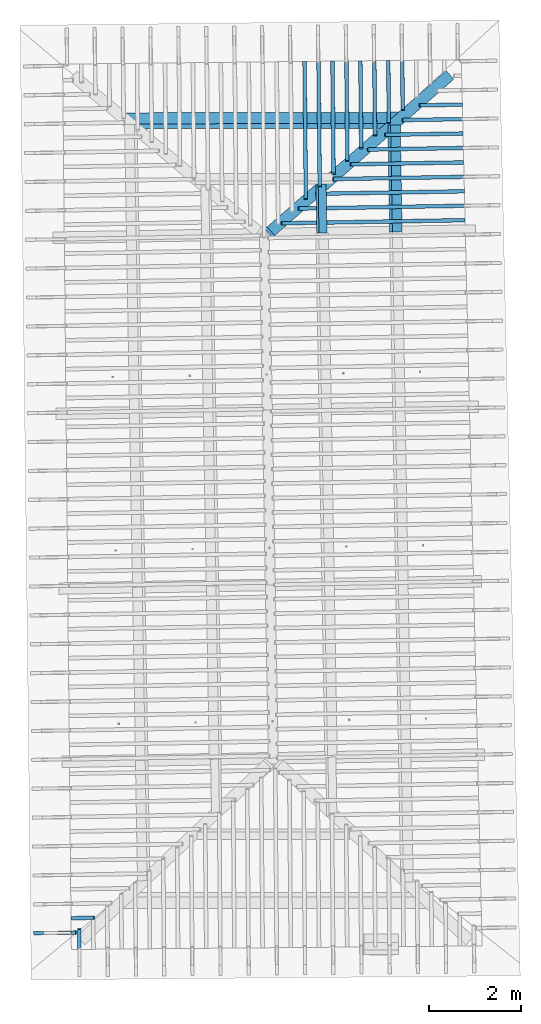
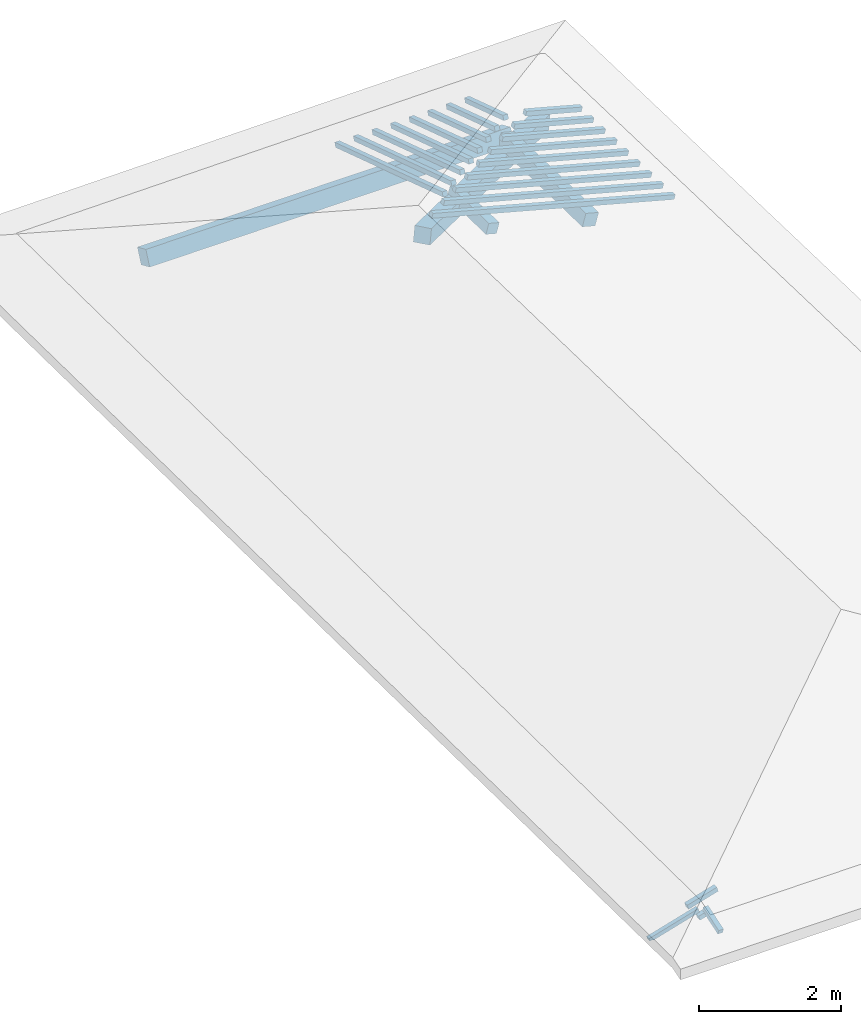
# One storey, part 8 of 19: 22 beams, 3 members, 5 elements without a shape of their own.
"""IFC4 building model written with IfcOpenShell, lengths in metres."""

from ifc_helpers import new_model, entity, si_unit, converted_unit, derived_unit, direction, frame, origin, place, context, subcontext, project, spatial, line, arc, indexed_curve, outline, extrude, source, transform, mapped, material, type_object, type_shapes, element, aggregate, save


model = new_model("IFC4")

# Units and contexts
model_context = context("Model", 3, precision=1e-05, world=origin(), true_north=direction((6.123233995736766e-17, 1.0)))
body_context = subcontext(model_context, "Body", "Model", "MODEL_VIEW")
ifc_project = project(units=[si_unit("LENGTHUNIT", "METRE"), si_unit("AREAUNIT", "SQUARE_METRE"), si_unit("VOLUMEUNIT", "CUBIC_METRE"), converted_unit("PLANEANGLEUNIT", "DEGREE", entity("IfcPlaneAngleMeasure", 0.017453292519943278), si_unit("PLANEANGLEUNIT", "RADIAN"), dimensions=[0, 0, 0, 0, 0, 0, 0]), derived_unit("THERMALTRANSMITTANCEUNIT", [(si_unit("MASSUNIT", "GRAM", prefix="KILO"), 1), (si_unit("THERMODYNAMICTEMPERATUREUNIT", "KELVIN"), -1), (si_unit("TIMEUNIT", "SECOND"), -3)])], contexts=[model_context])

# Site, building, storey
site_placement = place(None, origin())
site = spatial("IfcSite", under=ifc_project, at=site_placement, CompositionType="ELEMENT")
building_placement = place(site_placement, origin())
building = spatial("IfcBuilding", under=site, at=building_placement, CompositionType="ELEMENT")
storey_placement = place(building_placement, frame((0.0, 0.0, 3.28)))
storey = spatial("IfcBuildingStorey", under=building, at=storey_placement, Name="Livello Copertura", CompositionType="ELEMENT", Elevation=3.28)

# Beam
ifc_material = material(Name="Legno - Legno da costruzione", Category="Legno")
beam_type_1 = type_object("IfcBeamType", Name="Legno:250x250", PredefinedType="BEAM", material=ifc_material)
shared_shape_1 = source(origin(), body_context, "Body", "SweptSolid", [
    extrude(outline(indexed_curve([(-0.12500000000000164, -2.6915000000000004), (0.12500000000000164, -2.6915000000000004), (0.12500000000000164, 2.6915000000000004), (-0.12500000000000164, 2.6915000000000004), (-0.12500000000000164, -2.6915000000000004)], self_intersect=False)), frame((-0.09700000000000014, 0.0, -0.1250000000000054), z_axis=(0.0, 0.0, 1.0), x_axis=(0.0, 1.0, 0.0)), (0.0, 0.0, 1.0), 0.2499999999999999),
])
type_shapes(beam_type_1, [shared_shape_1])
beam_1_placement = place(storey_placement, frame((1.6960485545222057, 14.058149591074299, 0.36371203683741005), z_axis=(0.20387202036848304, 0.1778479374329003, 0.9627078011846253), x_axis=(-0.725463051111557, -0.6328583348061766, 0.2705433228491585)))
element("IfcBeam", 1, at=beam_1_placement, inside=storey, type_object=beam_type_1, material=ifc_material, Name="Legno:250x250", ObjectType="Legno:250x250", PredefinedType="BEAM", context=body_context, shape_type="MappedRepresentation", body=[
    mapped(shared_shape_1, transform((0.0, 0.0, 0.0), scale=1.0)),
])

# Members
member_type_1 = type_object("IfcMemberType", Name="Legno:220x220", PredefinedType="PURLIN", material=ifc_material)
shared_shape_2 = source(origin(), body_context, "Body", "SweptSolid", [
    extrude(outline(indexed_curve([(-1.1638894306878416, -0.11000000000000167), (1.1638894306878416, -0.11000000000000167), (1.1638894306878416, 0.11000000000000167), (-1.1638894306878416, 0.11000000000000167), (-1.1638894306878416, -0.11000000000000167)], self_intersect=False)), frame((0.7551105693121586, 0.0, -0.11000000000000543), z_axis=(0.0, 0.0, 1.0), x_axis=(-1.0, 0.0, 0.0)), (0.0, 0.0, 1.0), 0.21999999999999986),
])
type_shapes(member_type_1, [shared_shape_2])
member_1_placement = place(storey_placement, frame((2.531422696002869, 14.344178909537812, 0.36732198107242414), z_axis=(0.2688805697365734, 0.004594468182740755, 0.9631625667976581), x_axis=(0.017084897015614563, -0.9998540424951863, 0.0)))
element("IfcMember", 2, at=member_1_placement, inside=storey, type_object=member_type_1, material=ifc_material, Name="Legno:220x220", ObjectType="Legno:220x220", PredefinedType="PURLIN", context=body_context, shape_type="MappedRepresentation", body=[
    mapped(shared_shape_2, transform((0.0, 0.0, 0.0), scale=1.0)),
])
member_type_2 = type_object("IfcMemberType", Name="Legno:265x265", PredefinedType="PURLIN", material=ifc_material)
shared_shape_3 = source(origin(), body_context, "Body", "SweptSolid", [
    extrude(outline(indexed_curve([(-2.9789918250173737, -0.13250000000000164), (2.9789918250173737, -0.13250000000000164), (2.9789918250173737, 0.13250000000000164), (-2.9789918250173737, 0.13250000000000164), (-2.9789918250173737, -0.13250000000000164)], self_intersect=False)), frame((-0.06586492484490912, 0.0, -0.13250000000000545), z_axis=(0.0, 0.0, 1.0), x_axis=(-1.0, 0.0, 0.0)), (0.0, 0.0, 1.0), 0.2649999999999999),
])
type_shapes(member_type_2, [shared_shape_3])
member_2_placement = place(storey_placement, frame((-0.28854606470971034, 14.852295066283078, 0.3283530536152865), z_axis=(-0.003827735091052196, 0.39970199506726445, 0.9166371493580877), x_axis=(0.999992471364468, 0.002113791127369677, 0.0032540899577913683)))
element("IfcMember", 3, at=member_2_placement, inside=storey, type_object=member_type_2, material=ifc_material, Name="Legno:265x265", ObjectType="Legno:265x265", PredefinedType="PURLIN", context=body_context, shape_type="MappedRepresentation", body=[
    mapped(shared_shape_3, transform((0.0, 0.0, 0.0), scale=1.0)),
])
member_type_3 = type_object("IfcMemberType", Name="Legno:180x180", PredefinedType="PURLIN", material=ifc_material)
shared_shape_4 = source(origin(), body_context, "Body", "SweptSolid", [
    extrude(outline(indexed_curve([(-0.5343032276664149, -0.09000000000000168), (0.5343032276664149, -0.09000000000000168), (0.5343032276664149, 0.09000000000000168), (-0.5343032276664149, 0.09000000000000168), (-0.5343032276664149, -0.09000000000000168)], self_intersect=False)), frame((1.3846967723335852, 0.0, -0.09000000000000546), z_axis=(0.0, 0.0, 1.0), x_axis=(-1.0, 0.0, 0.0)), (0.0, 0.0, 1.0), 0.17999999999999997),
])
type_shapes(member_type_3, [shared_shape_4])
member_3_placement = place(storey_placement, frame((0.9179413523812053, 14.315851466891448, 0.7968332988440378), z_axis=(0.2688805697365734, 0.004594468182740752, 0.9631625667976581), x_axis=(0.017084897015614553, -0.9998540424951863, 0.0)))
element("IfcMember", 4, at=member_3_placement, inside=storey, type_object=member_type_3, material=ifc_material, Name="Legno:180x180", ObjectType="Legno:180x180", PredefinedType="PURLIN", context=body_context, shape_type="MappedRepresentation", body=[
    mapped(shared_shape_4, transform((0.0, 0.0, 0.0), scale=1.0)),
])

# Assembly, beam
assembly_1_placement = place(storey_placement, origin())
assembly_1 = element("IfcElementAssembly", 5, at=assembly_1_placement, inside=storey, Name="Sistema di travi strutturali:Sistema di travi strutturali", ObjectType="Sistema di travi strutturali:Sistema di travi strutturali", AssemblyPlace="NOTDEFINED", PredefinedType="BEAM_GRID")
beam_type_2 = type_object("IfcBeamType", Name="Legno:80x80", PredefinedType="JOIST", material=ifc_material)
shared_shape_5 = source(origin(), body_context, "Body", "SweptSolid", [
    extrude(outline(indexed_curve([(-0.2535, -0.04000000000000169), (0.2535, -0.04000000000000169), (0.2535, 0.04000000000000169), (-0.2535, 0.04000000000000169), (-0.2535, -0.04000000000000169)], self_intersect=False)), frame((0.0, 0.0, -0.040000000000005476), z_axis=(0.0, 0.0, 1.0), x_axis=(-1.0, 0.0, 0.0)), (0.0, 0.0, 1.0), 0.07999999999999997),
])
type_shapes(beam_type_2, [shared_shape_5])
beam_2_placement = place(assembly_1_placement, frame((-4.264641929408625, -2.534764252635881, 0.1468503372147414), z_axis=(-0.2688805697492535, -0.0045944674406682776, 0.9631625667976583), x_axis=(0.9630219859926786, 0.016455533263026904, 0.2689198206152654)))
beam_2 = element("IfcBeam", 6, at=beam_2_placement, type_object=beam_type_2, material=ifc_material, Name="Legno:80x80", ObjectType="Legno:80x80", PredefinedType="JOIST", context=body_context, shape_type="MappedRepresentation", body=[
    mapped(shared_shape_5, transform((0.0, 0.0, 0.0), scale=1.0)),
])

# Assembly, beams
assembly_2_placement = place(storey_placement, origin())
assembly_2 = element("IfcElementAssembly", 7, at=assembly_2_placement, inside=storey, Name="Sistema di travi strutturali:Sistema di travi strutturali", ObjectType="Sistema di travi strutturali:Sistema di travi strutturali", AssemblyPlace="NOTDEFINED", PredefinedType="BEAM_GRID")
beam_type_3 = type_object("IfcBeamType", Name="Legno:80x80", PredefinedType="JOIST", material=ifc_material)
shared_shape_6 = source(origin(), body_context, "Body", "SweptSolid", [
    extrude(outline(indexed_curve([(-2.0745, -0.04000000000000169), (2.0745, -0.04000000000000169), (2.0745, 0.04000000000000169), (-2.0745, 0.04000000000000169), (-2.0745, -0.04000000000000169)], self_intersect=False)), frame((0.0, 0.0, -0.040000000000005476), z_axis=(0.0, 0.0, 1.0), x_axis=(-1.0, 0.0, 0.0)), (0.0, 0.0, 1.0), 0.07999999999999997),
])
type_shapes(beam_type_3, [shared_shape_6])
beam_3_placement = place(assembly_2_placement, frame((2.0640077590166066, 12.644672862779435, 0.6611950307467415), z_axis=(0.26888056974925356, 0.0045944674406682776, 0.9631625667976583), x_axis=(-0.9630219859926786, -0.016455533263027858, 0.2689198206152655)))
beam_3 = element("IfcBeam", 8, at=beam_3_placement, type_object=beam_type_3, material=ifc_material, Name="Legno:80x80", ObjectType="Legno:80x80", PredefinedType="JOIST", context=body_context, shape_type="MappedRepresentation", body=[
    mapped(shared_shape_6, transform((0.0, 0.0, 0.0), scale=1.0)),
])
beam_type_4 = type_object("IfcBeamType", Name="Legno:80x80", PredefinedType="JOIST", material=ifc_material)
shared_shape_7 = source(origin(), body_context, "Body", "SweptSolid", [
    extrude(outline(indexed_curve([(-1.8750000000000002, -0.04000000000000169), (1.8750000000000002, -0.04000000000000169), (1.8750000000000002, 0.04000000000000169), (-1.8750000000000002, 0.04000000000000169), (-1.8750000000000002, -0.04000000000000169)], self_intersect=False)), frame((0.0, 0.0, -0.040000000000005476), z_axis=(0.0, 0.0, 1.0), x_axis=(-1.0, 0.0, 0.0)), (0.0, 0.0, 1.0), 0.07999999999999997),
])
type_shapes(beam_type_4, [shared_shape_7])
beam_4_placement = place(assembly_2_placement, frame((2.24875989282667, 12.962875778062536, 0.6081009491265847), z_axis=(0.2688805697492534, 0.004594467440668274, 0.9631625667976583), x_axis=(-0.9630219859926786, -0.01645553326302813, 0.2689198206152653)))
beam_4 = element("IfcBeam", 9, at=beam_4_placement, type_object=beam_type_4, material=ifc_material, Name="Legno:80x80", ObjectType="Legno:80x80", PredefinedType="JOIST", context=body_context, shape_type="MappedRepresentation", body=[
    mapped(shared_shape_7, transform((0.0, 0.0, 0.0), scale=1.0)),
])
beam_type_5 = type_object("IfcBeamType", Name="Legno:80x80", PredefinedType="JOIST", material=ifc_material)
shared_shape_8 = source(origin(), body_context, "Body", "SweptSolid", [
    extrude(outline(indexed_curve([(-1.6755, -0.04000000000000169), (1.6755, -0.04000000000000169), (1.6755, 0.04000000000000169), (-1.6755, 0.04000000000000169), (-1.6755, -0.04000000000000169)], self_intersect=False)), frame((0.0, 0.0, -0.040000000000005476), z_axis=(0.0, 0.0, 1.0), x_axis=(-1.0, 0.0, 0.0)), (0.0, 0.0, 1.0), 0.07999999999999997),
])
type_shapes(beam_type_5, [shared_shape_8])
beam_5_placement = place(assembly_2_placement, frame((2.433512026636735, 13.281078693345632, 0.555006867506429), z_axis=(0.2688805697492535, 0.004594467440668277, 0.9631625667976583), x_axis=(-0.9630219859926786, -0.01645553326302782, 0.2689198206152654)))
beam_5 = element("IfcBeam", 10, at=beam_5_placement, type_object=beam_type_5, material=ifc_material, Name="Legno:80x80", ObjectType="Legno:80x80", PredefinedType="JOIST", context=body_context, shape_type="MappedRepresentation", body=[
    mapped(shared_shape_8, transform((0.0, 0.0, 0.0), scale=1.0)),
])
beam_type_6 = type_object("IfcBeamType", Name="Legno:80x80", PredefinedType="JOIST", material=ifc_material)
shared_shape_9 = source(origin(), body_context, "Body", "SweptSolid", [
    extrude(outline(indexed_curve([(-1.4760000000000002, -0.04000000000000169), (1.4760000000000002, -0.04000000000000169), (1.4760000000000002, 0.04000000000000169), (-1.4760000000000002, 0.04000000000000169), (-1.4760000000000002, -0.04000000000000169)], self_intersect=False)), frame((0.0, 0.0, -0.040000000000005476), z_axis=(0.0, 0.0, 1.0), x_axis=(-1.0, 0.0, 0.0)), (0.0, 0.0, 1.0), 0.07999999999999997),
])
type_shapes(beam_type_6, [shared_shape_9])
beam_6_placement = place(assembly_2_placement, frame((2.618264160446798, 13.59928160862873, 0.5019127858862724), z_axis=(0.26888056974925345, 0.0045944674406682776, 0.9631625667976583), x_axis=(-0.9630219859926786, -0.01645553326302816, 0.26891982061526537)))
beam_6 = element("IfcBeam", 11, at=beam_6_placement, type_object=beam_type_6, material=ifc_material, Name="Legno:80x80", ObjectType="Legno:80x80", PredefinedType="JOIST", context=body_context, shape_type="MappedRepresentation", body=[
    mapped(shared_shape_9, transform((0.0, 0.0, 0.0), scale=1.0)),
])
beam_type_7 = type_object("IfcBeamType", Name="Legno:80x80", PredefinedType="JOIST", material=ifc_material)
shared_shape_10 = source(origin(), body_context, "Body", "SweptSolid", [
    extrude(outline(indexed_curve([(-1.2765, -0.04000000000000169), (1.2765, -0.04000000000000169), (1.2765, 0.04000000000000169), (-1.2765, 0.04000000000000169), (-1.2765, -0.04000000000000169)], self_intersect=False)), frame((0.0, 0.0, -0.040000000000005476), z_axis=(0.0, 0.0, 1.0), x_axis=(-1.0, 0.0, 0.0)), (0.0, 0.0, 1.0), 0.07999999999999997),
])
type_shapes(beam_type_7, [shared_shape_10])
beam_7_placement = place(assembly_2_placement, frame((2.8030162942568637, 13.91748452391183, 0.4488187042661157), z_axis=(0.26888056974925356, 0.0045944674406682776, 0.9631625667976583), x_axis=(-0.9630219859926786, -0.01645553326302776, 0.2689198206152655)))
beam_7 = element("IfcBeam", 12, at=beam_7_placement, type_object=beam_type_7, material=ifc_material, Name="Legno:80x80", ObjectType="Legno:80x80", PredefinedType="JOIST", context=body_context, shape_type="MappedRepresentation", body=[
    mapped(shared_shape_10, transform((0.0, 0.0, 0.0), scale=1.0)),
])
beam_type_8 = type_object("IfcBeamType", Name="Legno:80x80", PredefinedType="JOIST", material=ifc_material)
shared_shape_11 = source(origin(), body_context, "Body", "SweptSolid", [
    extrude(outline(indexed_curve([(-1.077, -0.04000000000000169), (1.077, -0.04000000000000169), (1.077, 0.04000000000000169), (-1.077, 0.04000000000000169), (-1.077, -0.04000000000000169)], self_intersect=False)), frame((0.0, 0.0, -0.040000000000005476), z_axis=(0.0, 0.0, 1.0), x_axis=(-1.0, 0.0, 0.0)), (0.0, 0.0, 1.0), 0.07999999999999997),
])
type_shapes(beam_type_8, [shared_shape_11])
beam_8_placement = place(assembly_2_placement, frame((2.9877684280669268, 14.235687439194926, 0.39572462264595887), z_axis=(0.26888056974925345, 0.004594467440668277, 0.9631625667976583), x_axis=(-0.9630219859926786, -0.016455533263028215, 0.26891982061526537)))
beam_8 = element("IfcBeam", 13, at=beam_8_placement, type_object=beam_type_8, material=ifc_material, Name="Legno:80x80", ObjectType="Legno:80x80", PredefinedType="JOIST", context=body_context, shape_type="MappedRepresentation", body=[
    mapped(shared_shape_11, transform((0.0, 0.0, 0.0), scale=1.0)),
])
beam_type_9 = type_object("IfcBeamType", Name="Legno:80x80", PredefinedType="JOIST", material=ifc_material)
shared_shape_12 = source(origin(), body_context, "Body", "SweptSolid", [
    extrude(outline(indexed_curve([(-0.8775000000000001, -0.04000000000000169), (0.8775000000000001, -0.04000000000000169), (0.8775000000000001, 0.04000000000000169), (-0.8775000000000001, 0.04000000000000169), (-0.8775000000000001, -0.04000000000000169)], self_intersect=False)), frame((0.0, 0.0, -0.040000000000005476), z_axis=(0.0, 0.0, 1.0), x_axis=(-1.0, 0.0, 0.0)), (0.0, 0.0, 1.0), 0.07999999999999997),
])
type_shapes(beam_type_9, [shared_shape_12])
beam_9_placement = place(assembly_2_placement, frame((3.1725205618769907, 14.553890354478021, 0.3426305410258026), z_axis=(0.2688805697492537, 0.004594467440668279, 0.9631625667976582), x_axis=(-0.9630219859926785, -0.016455533263027646, 0.2689198206152656)))
beam_9 = element("IfcBeam", 14, at=beam_9_placement, type_object=beam_type_9, material=ifc_material, Name="Legno:80x80", ObjectType="Legno:80x80", PredefinedType="JOIST", context=body_context, shape_type="MappedRepresentation", body=[
    mapped(shared_shape_12, transform((0.0, 0.0, 0.0), scale=1.0)),
])
beam_type_10 = type_object("IfcBeamType", Name="Legno:80x80", PredefinedType="JOIST", material=ifc_material)
shared_shape_13 = source(origin(), body_context, "Body", "SweptSolid", [
    extrude(outline(indexed_curve([(-0.678, -0.04000000000000169), (0.678, -0.04000000000000169), (0.678, 0.04000000000000169), (-0.678, 0.04000000000000169), (-0.678, -0.04000000000000169)], self_intersect=False)), frame((0.0, 0.0, -0.040000000000005476), z_axis=(0.0, 0.0, 1.0), x_axis=(-1.0, 0.0, 0.0)), (0.0, 0.0, 1.0), 0.07999999999999997),
])
type_shapes(beam_type_10, [shared_shape_13])
beam_10_placement = place(assembly_2_placement, frame((3.3572726956870556, 14.872093269761127, 0.28953645940564665), z_axis=(0.2688805697492534, 0.004594467440668275, 0.9631625667976583), x_axis=(-0.9630219859926786, -0.016455533263028378, 0.2689198206152653)))
beam_10 = element("IfcBeam", 15, at=beam_10_placement, type_object=beam_type_10, material=ifc_material, Name="Legno:80x80", ObjectType="Legno:80x80", PredefinedType="JOIST", context=body_context, shape_type="MappedRepresentation", body=[
    mapped(shared_shape_13, transform((0.0, 0.0, 0.0), scale=1.0)),
])
beam_type_11 = type_object("IfcBeamType", Name="Legno:80x80", PredefinedType="JOIST", material=ifc_material)
shared_shape_14 = source(origin(), body_context, "Body", "SweptSolid", [
    extrude(outline(indexed_curve([(-0.4785, -0.04000000000000169), (0.4785, -0.04000000000000169), (0.4785, 0.04000000000000169), (-0.4785, 0.04000000000000169), (-0.4785, -0.04000000000000169)], self_intersect=False)), frame((0.0, 0.0, -0.040000000000005476), z_axis=(0.0, 0.0, 1.0), x_axis=(-1.0, 0.0, 0.0)), (0.0, 0.0, 1.0), 0.07999999999999997),
])
type_shapes(beam_type_11, [shared_shape_14])
beam_11_placement = place(assembly_2_placement, frame((3.54202482949712, 15.19029618504422, 0.23644237778548982), z_axis=(0.2688805697492533, 0.0045944674406682715, 0.9631625667976583), x_axis=(-0.9630219859926786, -0.016455533263027414, 0.2689198206152652)))
beam_11 = element("IfcBeam", 16, at=beam_11_placement, type_object=beam_type_11, material=ifc_material, Name="Legno:80x80", ObjectType="Legno:80x80", PredefinedType="JOIST", context=body_context, shape_type="MappedRepresentation", body=[
    mapped(shared_shape_14, transform((0.0, 0.0, 0.0), scale=1.0)),
])
aggregate(assembly_2, [beam_3, beam_4, beam_5, beam_6, beam_7, beam_8, beam_9, beam_10, beam_11])

# Beam
beam_type_12 = type_object("IfcBeamType", Name="Legno:80x80", PredefinedType="JOIST", material=ifc_material)
shared_shape_15 = source(origin(), body_context, "Body", "SweptSolid", [
    extrude(outline(indexed_curve([(-0.05099999999999998, -0.04000000000000169), (0.05099999999999998, -0.04000000000000169), (0.05099999999999998, 0.04000000000000169), (-0.05099999999999998, 0.04000000000000169), (-0.05099999999999998, -0.04000000000000169)], self_intersect=False)), frame((0.0, 0.0, -0.040000000000005476), z_axis=(0.0, 0.0, 1.0), x_axis=(-1.0, 0.0, 0.0)), (0.0, 0.0, 1.0), 0.07999999999999997),
])
type_shapes(beam_type_12, [shared_shape_15])
beam_12_placement = place(assembly_1_placement, frame((-4.4562195057428795, -2.85308379692447, 0.09185027960865355), z_axis=(-0.26888056974925145, -0.004594467440668244, 0.9631625667976589), x_axis=(0.9630219859926792, 0.016455533263026494, 0.26891982061526337)))
beam_12 = element("IfcBeam", 17, at=beam_12_placement, type_object=beam_type_12, material=ifc_material, Name="Legno:80x80", ObjectType="Legno:80x80", PredefinedType="JOIST", context=body_context, shape_type="MappedRepresentation", body=[
    mapped(shared_shape_15, transform((0.0, 0.0, 0.0), scale=1.0)),
])

aggregate(assembly_1, [beam_2, beam_12])

# Assembly, beams
assembly_3_placement = place(storey_placement, origin())
assembly_3 = element("IfcElementAssembly", 18, at=assembly_3_placement, inside=storey, Name="Sistema di travi strutturali:Sistema di travi strutturali", ObjectType="Sistema di travi strutturali:Sistema di travi strutturali", AssemblyPlace="NOTDEFINED", PredefinedType="BEAM_GRID")
beam_type_13 = type_object("IfcBeamType", Name="Legno:80x80", PredefinedType="JOIST", material=ifc_material)
shared_shape_16 = source(origin(), body_context, "Body", "SweptSolid", [
    extrude(outline(indexed_curve([(-1.5685, -0.04000000000000169), (1.5685, -0.04000000000000169), (1.5685, 0.04000000000000169), (-1.5685, 0.04000000000000169), (-1.5685, -0.04000000000000169)], self_intersect=False)), frame((0.0, 0.0, -0.040000000000005476), z_axis=(0.0, 0.0, 1.0), x_axis=(-1.0, 0.0, 0.0)), (0.0, 0.0, 1.0), 0.07999999999999997),
])
type_shapes(beam_type_13, [shared_shape_16])
beam_13_placement = place(assembly_3_placement, frame((0.5877057732416664, 14.632289444593653, 0.5972728951450659), z_axis=(-0.00718665594214294, 0.3016187585889336, 0.953401529495123), x_axis=(0.009276659863625643, -0.9533650144726797, 0.30167713330857826)))
beam_13 = element("IfcBeam", 19, at=beam_13_placement, type_object=beam_type_13, material=ifc_material, Name="Legno:80x80", ObjectType="Legno:80x80", PredefinedType="JOIST", context=body_context, shape_type="MappedRepresentation", body=[
    mapped(shared_shape_16, transform((0.0, 0.0, 0.0), scale=1.0)),
])
beam_type_14 = type_object("IfcBeamType", Name="Legno:80x80", PredefinedType="JOIST", material=ifc_material)
shared_shape_17 = source(origin(), body_context, "Body", "SweptSolid", [
    extrude(outline(indexed_curve([(-1.4244999999999999, -0.04000000000000169), (1.4244999999999999, -0.04000000000000169), (1.4244999999999999, 0.04000000000000169), (-1.4244999999999999, 0.04000000000000169), (-1.4244999999999999, -0.04000000000000169)], self_intersect=False)), frame((0.0, 0.0, -0.040000000000005476), z_axis=(0.0, 0.0, 1.0), x_axis=(-1.0, 0.0, 0.0)), (0.0, 0.0, 1.0), 0.07999999999999997),
])
type_shapes(beam_type_14, [shared_shape_17])
beam_14_placement = place(assembly_3_placement, frame((0.8906509286822203, 14.77272500475281, 0.555128179123126), z_axis=(-0.007186655942142938, 0.30161875858893356, 0.953401529495123), x_axis=(0.009276659863625664, -0.9533650144726797, 0.3016771333085782)))
beam_14 = element("IfcBeam", 20, at=beam_14_placement, type_object=beam_type_14, material=ifc_material, Name="Legno:80x80", ObjectType="Legno:80x80", PredefinedType="JOIST", context=body_context, shape_type="MappedRepresentation", body=[
    mapped(shared_shape_17, transform((0.0, 0.0, 0.0), scale=1.0)),
])
beam_type_15 = type_object("IfcBeamType", Name="Legno:80x80", PredefinedType="JOIST", material=ifc_material)
shared_shape_18 = source(origin(), body_context, "Body", "SweptSolid", [
    extrude(outline(indexed_curve([(-1.2810000000000001, -0.04000000000000169), (1.2810000000000001, -0.04000000000000169), (1.2810000000000001, 0.04000000000000169), (-1.2810000000000001, 0.04000000000000169), (-1.2810000000000001, -0.04000000000000169)], self_intersect=False)), frame((0.0, 0.0, -0.040000000000005476), z_axis=(0.0, 0.0, 1.0), x_axis=(-1.0, 0.0, 0.0)), (0.0, 0.0, 1.0), 0.07999999999999997),
])
type_shapes(beam_type_15, [shared_shape_18])
beam_15_placement = place(assembly_3_placement, frame((1.1935960841227744, 14.913160564911975, 0.5129834631011825), z_axis=(-0.007186655942142939, 0.30161875858893383, 0.9534015294951229), x_axis=(0.009276659863625646, -0.9533650144726799, 0.3016771333085784)))
beam_15 = element("IfcBeam", 21, at=beam_15_placement, type_object=beam_type_15, material=ifc_material, Name="Legno:80x80", ObjectType="Legno:80x80", PredefinedType="JOIST", context=body_context, shape_type="MappedRepresentation", body=[
    mapped(shared_shape_18, transform((0.0, 0.0, 0.0), scale=1.0)),
])
beam_type_16 = type_object("IfcBeamType", Name="Legno:80x80", PredefinedType="JOIST", material=ifc_material)
shared_shape_19 = source(origin(), body_context, "Body", "SweptSolid", [
    extrude(outline(indexed_curve([(-1.137, -0.04000000000000169), (1.137, -0.04000000000000169), (1.137, 0.04000000000000169), (-1.137, 0.04000000000000169), (-1.137, -0.04000000000000169)], self_intersect=False)), frame((0.0, 0.0, -0.040000000000005476), z_axis=(0.0, 0.0, 1.0), x_axis=(-1.0, 0.0, 0.0)), (0.0, 0.0, 1.0), 0.07999999999999997),
])
type_shapes(beam_type_16, [shared_shape_19])
beam_16_placement = place(assembly_3_placement, frame((1.4965412395633273, 15.053596125071131, 0.470838747079239), z_axis=(-0.0071866559421429384, 0.3016187585889338, 0.9534015294951229), x_axis=(0.009276659863625674, -0.9533650144726799, 0.30167713330857837)))
beam_16 = element("IfcBeam", 22, at=beam_16_placement, type_object=beam_type_16, material=ifc_material, Name="Legno:80x80", ObjectType="Legno:80x80", PredefinedType="JOIST", context=body_context, shape_type="MappedRepresentation", body=[
    mapped(shared_shape_19, transform((0.0, 0.0, 0.0), scale=1.0)),
])
beam_type_17 = type_object("IfcBeamType", Name="Legno:80x80", PredefinedType="JOIST", material=ifc_material)
shared_shape_20 = source(origin(), body_context, "Body", "SweptSolid", [
    extrude(outline(indexed_curve([(-0.9935, -0.04000000000000169), (0.9935, -0.04000000000000169), (0.9935, 0.04000000000000169), (-0.9935, 0.04000000000000169), (-0.9935, -0.04000000000000169)], self_intersect=False)), frame((0.0, 0.0, -0.040000000000005476), z_axis=(0.0, 0.0, 1.0), x_axis=(-1.0, 0.0, 0.0)), (0.0, 0.0, 1.0), 0.07999999999999997),
])
type_shapes(beam_type_17, [shared_shape_20])
beam_17_placement = place(assembly_3_placement, frame((1.799486395003882, 15.194031685230291, 0.42869403105730086), z_axis=(-0.007186655942142939, 0.3016187585889337, 0.953401529495123), x_axis=(0.009276659863625709, -0.9533650144726799, 0.3016771333085783)))
beam_17 = element("IfcBeam", 23, at=beam_17_placement, type_object=beam_type_17, material=ifc_material, Name="Legno:80x80", ObjectType="Legno:80x80", PredefinedType="JOIST", context=body_context, shape_type="MappedRepresentation", body=[
    mapped(shared_shape_20, transform((0.0, 0.0, 0.0), scale=1.0)),
])
beam_type_18 = type_object("IfcBeamType", Name="Legno:80x80", PredefinedType="JOIST", material=ifc_material)
shared_shape_21 = source(origin(), body_context, "Body", "SweptSolid", [
    extrude(outline(indexed_curve([(-0.8495, -0.04000000000000169), (0.8495, -0.04000000000000169), (0.8495, 0.04000000000000169), (-0.8495, 0.04000000000000169), (-0.8495, -0.04000000000000169)], self_intersect=False)), frame((0.0, 0.0, -0.040000000000005476), z_axis=(0.0, 0.0, 1.0), x_axis=(-1.0, 0.0, 0.0)), (0.0, 0.0, 1.0), 0.07999999999999997),
])
type_shapes(beam_type_18, [shared_shape_21])
beam_18_placement = place(assembly_3_placement, frame((2.102431550444434, 15.334467245389447, 0.3865493150353583), z_axis=(-0.00718665594214294, 0.3016187585889339, 0.9534015294951229), x_axis=(0.009276659863625596, -0.9533650144726799, 0.3016771333085785)))
beam_18 = element("IfcBeam", 24, at=beam_18_placement, type_object=beam_type_18, material=ifc_material, Name="Legno:80x80", ObjectType="Legno:80x80", PredefinedType="JOIST", context=body_context, shape_type="MappedRepresentation", body=[
    mapped(shared_shape_21, transform((0.0, 0.0, 0.0), scale=1.0)),
])
beam_type_19 = type_object("IfcBeamType", Name="Legno:80x80", PredefinedType="JOIST", material=ifc_material)
shared_shape_22 = source(origin(), body_context, "Body", "SweptSolid", [
    extrude(outline(indexed_curve([(-0.7060000000000001, -0.04000000000000169), (0.7060000000000001, -0.04000000000000169), (0.7060000000000001, 0.04000000000000169), (-0.7060000000000001, 0.04000000000000169), (-0.7060000000000001, -0.04000000000000169)], self_intersect=False)), frame((0.0, 0.0, -0.040000000000005476), z_axis=(0.0, 0.0, 1.0), x_axis=(-1.0, 0.0, 0.0)), (0.0, 0.0, 1.0), 0.07999999999999997),
])
type_shapes(beam_type_19, [shared_shape_22])
beam_19_placement = place(assembly_3_placement, frame((2.4053767058849878, 15.474902805548608, 0.3444045990134157), z_axis=(-0.0071866559421429384, 0.30161875858893383, 0.9534015294951229), x_axis=(0.009276659863625629, -0.9533650144726799, 0.3016771333085784)))
beam_19 = element("IfcBeam", 25, at=beam_19_placement, type_object=beam_type_19, material=ifc_material, Name="Legno:80x80", ObjectType="Legno:80x80", PredefinedType="JOIST", context=body_context, shape_type="MappedRepresentation", body=[
    mapped(shared_shape_22, transform((0.0, 0.0, 0.0), scale=1.0)),
])
beam_type_20 = type_object("IfcBeamType", Name="Legno:80x80", PredefinedType="JOIST", material=ifc_material)
shared_shape_23 = source(origin(), body_context, "Body", "SweptSolid", [
    extrude(outline(indexed_curve([(-0.562, -0.04000000000000169), (0.562, -0.04000000000000169), (0.562, 0.04000000000000169), (-0.562, 0.04000000000000169), (-0.562, -0.04000000000000169)], self_intersect=False)), frame((0.0, 0.0, -0.040000000000005476), z_axis=(0.0, 0.0, 1.0), x_axis=(-1.0, 0.0, 0.0)), (0.0, 0.0, 1.0), 0.07999999999999997),
])
type_shapes(beam_type_20, [shared_shape_23])
beam_20_placement = place(assembly_3_placement, frame((2.708321861325542, 15.615338365707757, 0.30225988299147666), z_axis=(-0.0071866559421429384, 0.3016187585889336, 0.953401529495123), x_axis=(0.00927665986362568, -0.9533650144726797, 0.30167713330857826)))
beam_20 = element("IfcBeam", 26, at=beam_20_placement, type_object=beam_type_20, material=ifc_material, Name="Legno:80x80", ObjectType="Legno:80x80", PredefinedType="JOIST", context=body_context, shape_type="MappedRepresentation", body=[
    mapped(shared_shape_23, transform((0.0, 0.0, 0.0), scale=1.0)),
])
aggregate(assembly_3, [beam_13, beam_14, beam_15, beam_16, beam_17, beam_18, beam_19, beam_20])

# Assembly, beam
assembly_4_placement = place(storey_placement, origin())
assembly_4 = element("IfcElementAssembly", 27, at=assembly_4_placement, inside=storey, Name="Sistema di travi strutturali:Sistema di travi strutturali", ObjectType="Sistema di travi strutturali:Sistema di travi strutturali", AssemblyPlace="NOTDEFINED", PredefinedType="BEAM_GRID")
beam_type_21 = type_object("IfcBeamType", Name="Legno:80x80", PredefinedType="JOIST", material=ifc_material)
shared_shape_24 = source(origin(), body_context, "Body", "SweptSolid", [
    extrude(outline(indexed_curve([(-0.2285, -0.04000000000000169), (0.2285, -0.04000000000000169), (0.2285, 0.04000000000000169), (-0.2285, 0.04000000000000169), (-0.2285, -0.04000000000000169)], self_intersect=False)), frame((0.0, 0.0, -0.040000000000005476), z_axis=(0.0, 0.0, 1.0), x_axis=(-1.0, 0.0, 0.0)), (0.0, 0.0, 1.0), 0.07999999999999997),
])
type_shapes(beam_type_21, [shared_shape_24])
beam_21_placement = place(assembly_4_placement, frame((-4.338025255686483, -2.9907194967913373, 0.05402418171011092), z_axis=(0.00339332276243599, -0.3255504700615086, 0.9455185755993168), x_axis=(-0.007932350194779498, 0.9454855083215803, 0.325567552704919)))
beam_21 = element("IfcBeam", 28, at=beam_21_placement, type_object=beam_type_21, material=ifc_material, Name="Legno:80x80", ObjectType="Legno:80x80", PredefinedType="JOIST", context=body_context, shape_type="MappedRepresentation", body=[
    mapped(shared_shape_24, transform((0.0, 0.0, 0.0), scale=1.0)),
])
aggregate(assembly_4, [beam_21])

assembly_5_placement = place(storey_placement, origin())
assembly_5 = element("IfcElementAssembly", 29, at=assembly_5_placement, inside=storey, Name="Sistema di travi strutturali:Sistema di travi strutturali", ObjectType="Sistema di travi strutturali:Sistema di travi strutturali", AssemblyPlace="NOTDEFINED", PredefinedType="BEAM_GRID")
beam_type_22 = type_object("IfcBeamType", Name="70x70:70x70", PredefinedType="JOIST", material=ifc_material)
shared_shape_25 = source(origin(), body_context, "Body", "SweptSolid", [
    extrude(outline(indexed_curve([(-0.0435714285714315, -0.5689999999999996), (0.02642857142856849, -0.5689999999999996), (0.02642857142856849, 0.17800000000000055), (0.012428571428584397, 0.17799999999999716), (0.026181867029378917, 0.2017096045279018), (0.018428571428570725, 0.2280000000000007), (0.006014118110847691, 0.2509955755149836), (0.0034285714285708967, 0.2770000000000005), (-0.0435714285714315, 0.2770000000000005)], segments=[line(1, 2, 3, 4), arc(4, 5, 6), arc(6, 7, 8), line(8, 9, 1)], self_intersect=False)), frame((-0.11099999999999956, -0.03500000000000078, -0.008571428571433228), z_axis=(0.0, 1.0, 0.0), x_axis=(0.0, 0.0, -1.0)), (0.0, 0.0, 1.0), 0.06999999999999999),
])
type_shapes(beam_type_22, [shared_shape_25])
beam_22_placement = place(assembly_5_placement, frame((-4.948028853992841, -2.8614875355793723, 0.0915866115454056), z_axis=(-0.26888056974925273, -0.004594467440668775, 0.9631625667976585), x_axis=(0.9630219859926787, 0.016455533263032885, 0.26891982061526465)))
beam_22 = element("IfcBeam", 30, at=beam_22_placement, type_object=beam_type_22, material=ifc_material, Name="70x70:70x70", ObjectType="70x70:70x70", PredefinedType="JOIST", context=body_context, shape_type="MappedRepresentation", body=[
    mapped(shared_shape_25, transform((0.0, 0.0, 0.0), scale=1.0)),
])
aggregate(assembly_5, [beam_22])

save(model, "model.ifc")
